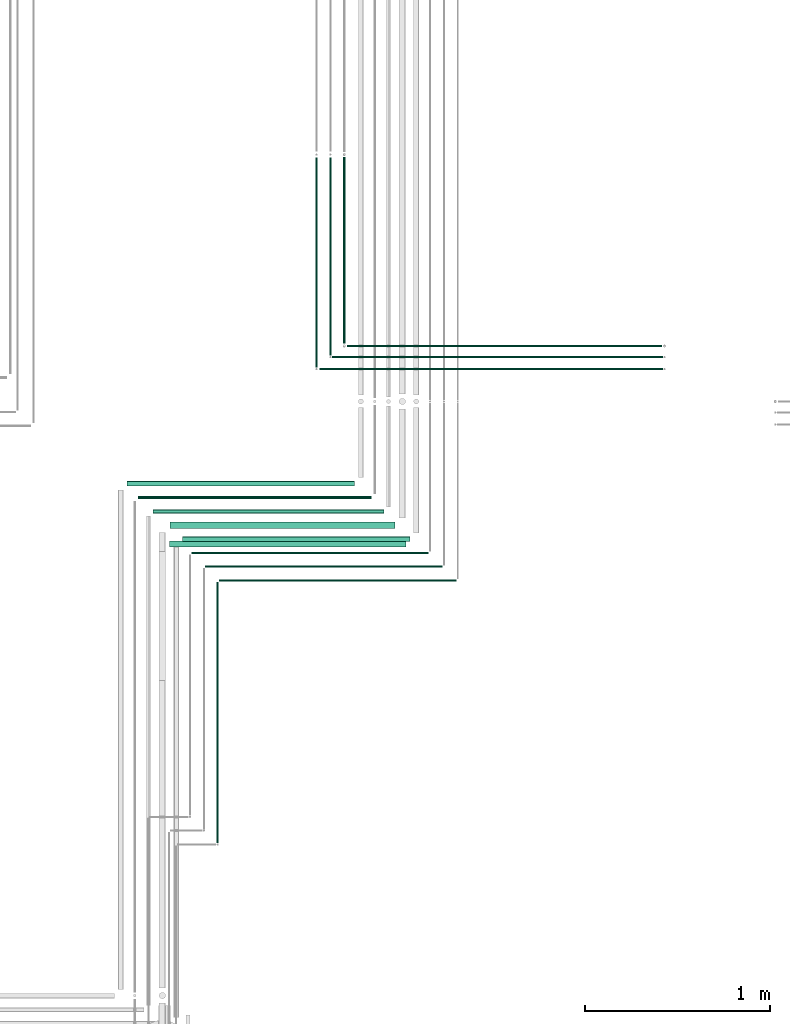
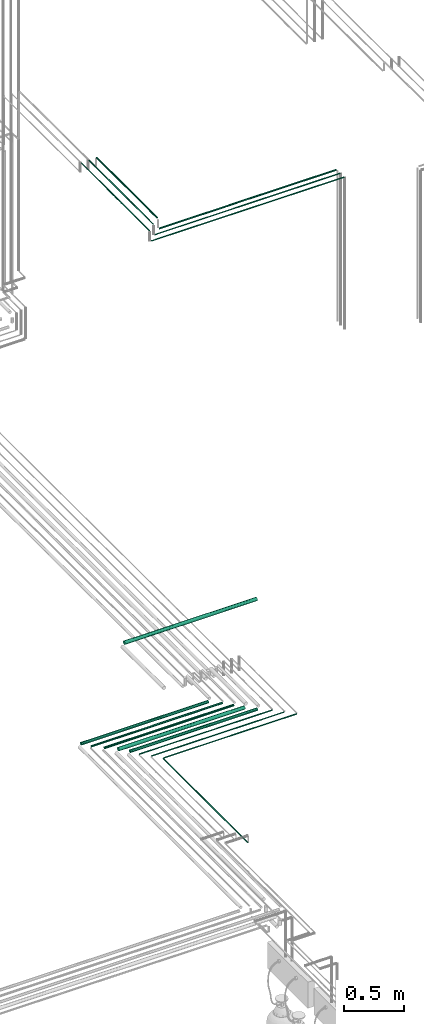
# One storey, part 69 of 331: 16 flow segments.
"""IFC2X3 building model written with IfcOpenShell, lengths in millimetres."""

from ifc_helpers import new_model, entity, si_unit, converted_unit, derived_unit, direction, frame, frame_2d, origin, origin_2d_with_axis, place, context, subcontext, project, spatial, circle, extrude, type_object, element, save


model = new_model("IFC2X3")

# Units and contexts
model_context = context("Model", 3, precision=0.01, world=origin(), true_north=direction((6.12303176911189e-17, 1.0)))
body_context = subcontext(model_context, "Body", "Model", "MODEL_VIEW")
ifc_project = project(units=[si_unit("LENGTHUNIT", "METRE", prefix="MILLI"), si_unit("AREAUNIT", "SQUARE_METRE"), si_unit("VOLUMEUNIT", "CUBIC_METRE"), converted_unit("PLANEANGLEUNIT", "DEGREE", entity("IfcRatioMeasure", 0.0174532925199433), si_unit("PLANEANGLEUNIT", "RADIAN"), dimensions=[0, 0, 0, 0, 0, 0, 0]), si_unit("MASSUNIT", "GRAM", prefix="KILO"), derived_unit("MASSDENSITYUNIT", [(si_unit("MASSUNIT", "GRAM", prefix="KILO"), 1), (si_unit("LENGTHUNIT", "METRE"), -3)]), derived_unit("MOMENTOFINERTIAUNIT", [(si_unit("LENGTHUNIT", "METRE"), 4)]), si_unit("TIMEUNIT", "SECOND"), si_unit("FREQUENCYUNIT", "HERTZ"), si_unit("THERMODYNAMICTEMPERATUREUNIT", "DEGREE_CELSIUS"), derived_unit("THERMALTRANSMITTANCEUNIT", [(si_unit("MASSUNIT", "GRAM", prefix="KILO"), 1), (si_unit("THERMODYNAMICTEMPERATUREUNIT", "KELVIN"), -1), (si_unit("TIMEUNIT", "SECOND"), -3)]), derived_unit("VOLUMETRICFLOWRATEUNIT", [(si_unit("LENGTHUNIT", "METRE"), 3), (si_unit("TIMEUNIT", "SECOND"), -1)]), derived_unit("MASSFLOWRATEUNIT", [(si_unit("MASSUNIT", "GRAM", prefix="KILO"), 1), (si_unit("TIMEUNIT", "SECOND"), -1)]), derived_unit("ROTATIONALFREQUENCYUNIT", [(si_unit("TIMEUNIT", "SECOND"), -1)]), si_unit("ELECTRICCURRENTUNIT", "AMPERE"), si_unit("ELECTRICVOLTAGEUNIT", "VOLT"), si_unit("POWERUNIT", "WATT"), si_unit("FORCEUNIT", "NEWTON", prefix="KILO"), si_unit("ILLUMINANCEUNIT", "LUX"), si_unit("LUMINOUSFLUXUNIT", "LUMEN"), si_unit("LUMINOUSINTENSITYUNIT", "CANDELA"), derived_unit("USERDEFINED", [(si_unit("MASSUNIT", "GRAM", prefix="KILO"), -1), (si_unit("LENGTHUNIT", "METRE"), -2), (si_unit("TIMEUNIT", "SECOND"), 3), (si_unit("LUMINOUSFLUXUNIT", "LUMEN"), 1)]), derived_unit("LINEARVELOCITYUNIT", [(si_unit("LENGTHUNIT", "METRE"), 1), (si_unit("TIMEUNIT", "SECOND"), -1)]), si_unit("PRESSUREUNIT", "PASCAL"), derived_unit("USERDEFINED", [(si_unit("LENGTHUNIT", "METRE"), -2), (si_unit("MASSUNIT", "GRAM", prefix="KILO"), 1), (si_unit("TIMEUNIT", "SECOND"), -2)]), derived_unit("LINEARFORCEUNIT", [(si_unit("MASSUNIT", "GRAM", prefix="KILO"), 1), (si_unit("LENGTHUNIT", "METRE"), 1), (si_unit("TIMEUNIT", "SECOND"), -2), (si_unit("LENGTHUNIT", "METRE"), -1)]), derived_unit("PLANARFORCEUNIT", [(si_unit("MASSUNIT", "GRAM", prefix="KILO"), 1), (si_unit("LENGTHUNIT", "METRE"), 1), (si_unit("TIMEUNIT", "SECOND"), -2), (si_unit("LENGTHUNIT", "METRE"), -2)])], contexts=[model_context])

# Site, building, storey
site_placement = place(None, frame((0.0, -0.00077364408347762, 0.0)))
site = spatial("IfcSite", under=ifc_project, at=site_placement, CompositionType="ELEMENT")
building_placement = place(site_placement, origin())
building = spatial("IfcBuilding", under=site, at=building_placement, CompositionType="ELEMENT")
storey_placement = place(building_placement, origin())
storey = spatial("IfcBuildingStorey", under=building, at=storey_placement, CompositionType="ELEMENT", Elevation=0.0)

# Flow segments
pipe_segment_type = type_object("IfcPipeSegmentType", PredefinedType="NOTDEFINED")
flow_segment_1_placement = place(building_placement, frame((64059.0036168841, 2114.1546573586, 2834.40472776411)))
element("IfcFlowSegment", 1, at=flow_segment_1_placement, inside=storey, type_object=pipe_segment_type, context=body_context, shape_type="SweptSolid", body=[
    extrude(circle(Radius=14.0, at=origin_2d_with_axis()), frame((0.0, 15.595272235916, 15.595272235916), z_axis=(1.0, 0.0, 0.0), x_axis=(0.0, -1.0, 0.0)), (0.0, 0.0, 1.0), 1232.10828630988),
])
flow_segment_2_placement = place(building_placement, frame((64118.0036168841, 2045.6546573586, 2840.90472776409)))
element("IfcFlowSegment", 2, at=flow_segment_2_placement, inside=storey, type_object=pipe_segment_type, context=body_context, shape_type="SweptSolid", body=[
    extrude(circle(Radius=7.5, at=origin_2d_with_axis()), frame((0.0, 9.09527223591582, 9.09527223591582), z_axis=(1.0, 0.0, 0.0), x_axis=(0.0, -1.0, 0.0)), (0.0, 0.0, 1.0), 1264.10828630987),
])
flow_segment_3_placement = place(building_placement, frame((64199.0036168841, 1967.1546573586, 2837.40472776409)))
element("IfcFlowSegment", 3, at=flow_segment_3_placement, inside=storey, type_object=pipe_segment_type, context=body_context, shape_type="SweptSolid", body=[
    extrude(circle(Radius=11.0, at=origin_2d_with_axis()), frame((0.0, 12.5952722359158, 12.5952722359161), z_axis=(1.0, 0.0, 0.0), x_axis=(0.0, -1.0, 0.0)), (0.0, 0.0, 1.0), 1252.10828630985),
])
flow_segment_4_placement = place(building_placement, frame((64289.4972907715, 1783.83499464522, 3980.90472776408)))
element("IfcFlowSegment", 4, at=flow_segment_4_placement, inside=storey, type_object=pipe_segment_type, context=body_context, shape_type="SweptSolid", body=[
    extrude(circle(Radius=17.5, at=frame_2d((2.70716782324598e-13, 0.0), x_axis=(1.0, 0.0))), frame((0.0, 19.0952722359244, 19.0952722359157), z_axis=(1.0, 0.0, 0.0), x_axis=(0.0, -1.0, 0.0)), (0.0, 0.0, 1.0), 1280.00000000001),
])
flow_segment_5_placement = place(building_placement, frame((64290.0036168841, 1885.6546573586, 2830.90472776409)))
element("IfcFlowSegment", 5, at=flow_segment_5_placement, inside=storey, type_object=pipe_segment_type, context=body_context, shape_type="SweptSolid", body=[
    extrude(circle(Radius=17.5, at=origin_2d_with_axis()), frame((0.0, 19.0952722359165, 19.0952722359157), z_axis=(1.0, 0.0, 0.0), x_axis=(0.0, -1.0, 0.0)), (0.0, 0.0, 1.0), 1220.10828630986),
])
flow_segment_6_placement = place(building_placement, frame((64359.0036168841, 1814.15465735859, 2834.40472776409)))
element("IfcFlowSegment", 6, at=flow_segment_6_placement, inside=storey, type_object=pipe_segment_type, context=body_context, shape_type="SweptSolid", body=[
    extrude(circle(Radius=14.0, at=origin_2d_with_axis()), frame((0.0, 15.595272235916, 15.595272235916), z_axis=(1.0, 0.0, 0.0), x_axis=(0.0, 1.0, 0.0)), (0.0, 0.0, 1.0), 1232.10828630987),
])
for number, where in (
    (7, (64408.4972907715, 1749.1546573586, 2844.4047277641)),
    (8, (64483.4972907715, 1674.1546573586, 2844.4047277641)),
):
    element("IfcFlowSegment", number, at=place(building_placement, frame(where)), inside=storey, type_object=pipe_segment_type, context=body_context, shape_type="SweptSolid", body=[
        extrude(circle(Radius=4.0, at=origin_2d_with_axis()), frame((0.0, 5.5952722359158, 5.59527223591607), z_axis=(1.0, 0.0, 0.0), x_axis=(0.0, -1.0, 0.0)), (0.0, 0.0, 1.0), 1282.61461242247),
    ])
flow_segment_7_placement = place(building_placement, frame((64543.9020185356, 184.0, 2844.40472776407)))
element("IfcFlowSegment", 9, at=flow_segment_7_placement, inside=storey, type_object=pipe_segment_type, context=body_context, shape_type="SweptSolid", body=[
    extrude(circle(Radius=4.0, at=frame_2d((0.0, -4.79459270766112e-29), x_axis=(1.0, 0.0))), frame((5.59527223593232, 0.0, 5.59527223591607), z_axis=(0.0, 1.0, 0.0), x_axis=(1.0, 0.0, 0.0)), (0.0, 0.0, 1.0), 1411.74992959433),
])
flow_segment_8_placement = place(building_placement, frame((64558.4972907715, 1599.1546573586, 2844.40472776409)))
element("IfcFlowSegment", 10, at=flow_segment_8_placement, inside=storey, type_object=pipe_segment_type, context=body_context, shape_type="SweptSolid", body=[
    extrude(circle(Radius=4.0, at=origin_2d_with_axis()), frame((0.0, 5.5952722359158, 5.59527223591607), z_axis=(1.0, 0.0, 0.0), x_axis=(0.0, -1.0, 0.0)), (0.0, 0.0, 1.0), 1282.61461242246),
])
flow_segment_9_placement = place(building_placement, frame((65249.1052890602, 2867.40454771039, 7242.40472776409)))
element("IfcFlowSegment", 11, at=flow_segment_9_placement, inside=storey, type_object=pipe_segment_type, context=body_context, shape_type="SweptSolid", body=[
    extrude(circle(Radius=6.0, at=frame_2d((4.33146851719357e-12, 0.0), x_axis=(1.0, 0.0))), frame((0.0, 7.59527223592049, 7.59527223591562), z_axis=(1.0, 0.0, 0.0), x_axis=(0.0, 1.0, 0.0)), (0.0, 0.0, 1.0), 1706.89385644759),
])
flow_segment_10_placement = place(building_placement, frame((65170.1052890602, 2809.40537015912, 7244.40472776408)))
element("IfcFlowSegment", 12, at=flow_segment_10_placement, inside=storey, type_object=pipe_segment_type, context=body_context, shape_type="SweptSolid", body=[
    extrude(circle(Radius=4.0, at=frame_2d((0.0, -1.08286712929839e-12), x_axis=(1.0, 0.0))), frame((0.0, 5.59527223591607, 5.59527223591499), z_axis=(1.0, 0.0, 0.0), x_axis=(0.0, -1.0, 0.0)), (0.0, 0.0, 1.0), 1789.89385644756),
])
flow_segment_11_placement = place(building_placement, frame((65102.1052890602, 2744.40537015912, 7244.40472776409)))
element("IfcFlowSegment", 13, at=flow_segment_11_placement, inside=storey, type_object=pipe_segment_type, context=body_context, shape_type="SweptSolid", body=[
    extrude(circle(Radius=4.0, at=frame_2d((5.41433564649196e-13, 0.0), x_axis=(1.0, 0.0))), frame((0.0, 5.59527223591661, 5.59527223591607), z_axis=(1.0, 0.0, 0.0), x_axis=(0.0, 1.0, 0.0)), (0.0, 0.0, 1.0), 1857.89385644756),
])
flow_segment_12_placement = place(building_placement, frame((65154.5100168243, 2825.00064239504, 7350.40472776408)))
element("IfcFlowSegment", 14, at=flow_segment_12_placement, inside=storey, type_object=pipe_segment_type, context=body_context, shape_type="SweptSolid", body=[
    extrude(circle(Radius=4.0, at=frame_2d((1.73258740687743e-11, 2.16573425859679e-12), x_axis=(1.0, 0.0))), frame((5.59527223593232, 0.0, 5.59527223591716), z_axis=(0.0, 1.0, 0.0), x_axis=(-1.0, 0.0, 0.0)), (0.0, 0.0, 1.0), 1070.49921031258),
])
flow_segment_13_placement = place(building_placement, frame((65079.5100168243, 2760.00064239505, 7350.40472776408)))
element("IfcFlowSegment", 15, at=flow_segment_13_placement, inside=storey, type_object=pipe_segment_type, context=body_context, shape_type="SweptSolid", body=[
    extrude(circle(Radius=4.0, at=frame_2d((8.66293703438714e-12, 2.16573425859679e-12), x_axis=(1.0, 0.0))), frame((5.59527223592365, 0.0, 5.59527223591824), z_axis=(0.0, 1.0, 0.0), x_axis=(-1.0, 0.0, 0.0)), (0.0, 0.0, 1.0), 1135.49921031258),
])
flow_segment_14_placement = place(building_placement, frame((65227.5100168243, 2889.41432859279, 7348.40472776408)))
element("IfcFlowSegment", 16, at=flow_segment_14_placement, inside=storey, type_object=pipe_segment_type, context=body_context, shape_type="SweptSolid", body=[
    extrude(circle(Radius=6.0, at=frame_2d((0.0, -2.16573425859679e-12), x_axis=(1.0, 0.0))), frame((7.59527223591454, 0.0, 7.59527223591454), z_axis=(0.0, 1.0, 0.0), x_axis=(-1.0, 0.0, 0.0)), (0.0, 0.0, 1.0), 1009.08552411484),
])

save(model, "model.ifc")
